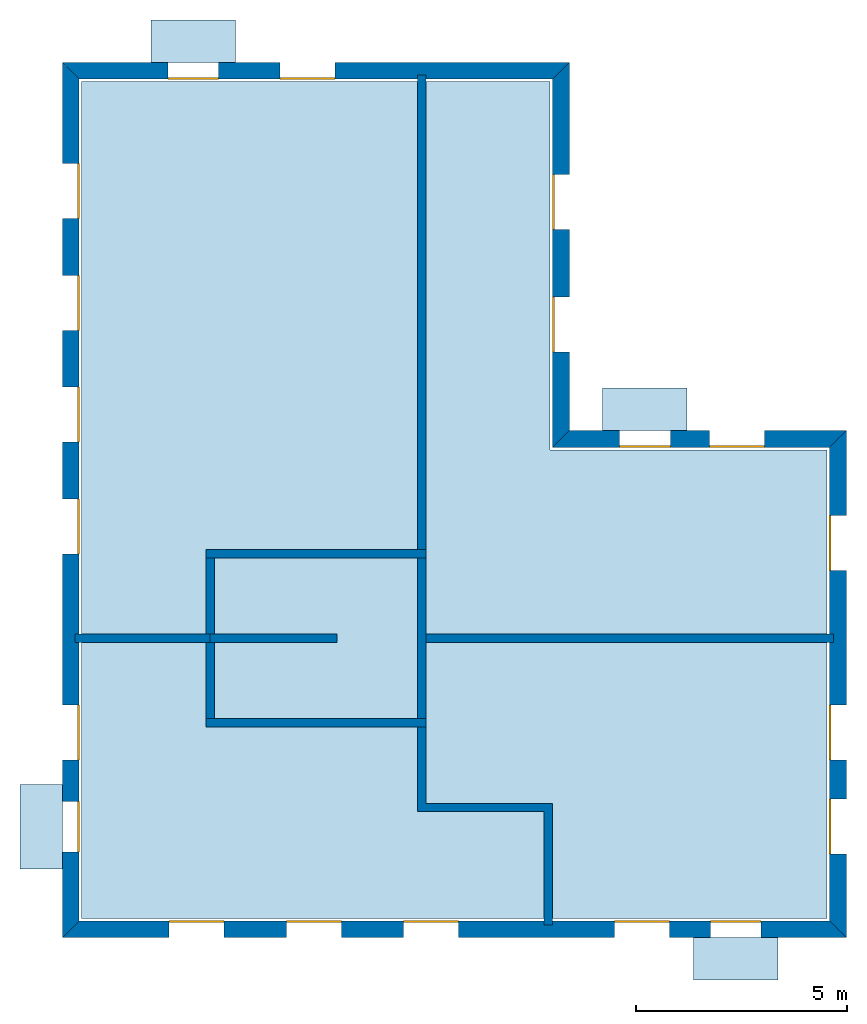
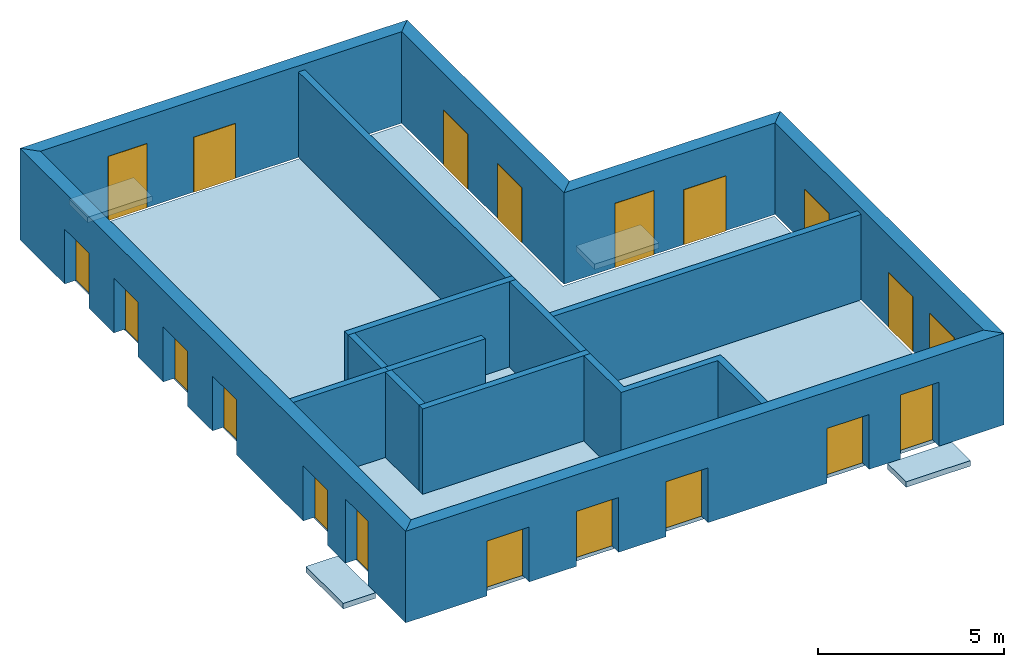
# One storey: 20 windows, 15 walls, 5 slabs, 20 openings.
"""IFC4 building model written with IfcOpenShell, lengths in metres."""

from ifc_helpers import new_model, si_unit, frame, origin_with_axes, place, context, subcontext, project, spatial, line, indexed_curve, outline, extrude, element, fill, save


model = new_model("IFC4")

# Units and contexts
model_context = context("Model", 3, precision=1e-05, world=origin_with_axes())
body_context = subcontext(model_context, "Body", "Model", "MODEL_VIEW")
ifc_project = project(units=[si_unit("AREAUNIT", "SQUARE_METRE"), si_unit("VOLUMEUNIT", "CUBIC_METRE"), si_unit("LENGTHUNIT", "METRE")], contexts=[model_context])

# Site, building, storey
site = spatial("IfcSite", under=ifc_project)
building = spatial("IfcBuilding", under=site, Name="Building 2")
storey_placement = place(None, frame((0.0, 0.0, 4.0), z_axis=(0.0, 0.0, 1.0), x_axis=(1.0, 0.0, 0.0)))
storey = spatial("IfcBuildingStorey", under=building, at=storey_placement, Name="02 Storey")

# Slabs
slab_1_placement = place(storey_placement, origin_with_axes())
element("IfcSlab", 1, at=slab_1_placement, inside=storey, Name="Slab", context=body_context, shape_type="SweptSolid", body=[
    extrude(outline(indexed_curve([(22.079464, -3.619175), (15.533354, -3.619175), (15.533354, 5.0882), (4.453354, 5.0882), (4.453354, -14.699175), (22.079464, -14.699175)], segments=[line(1, 2), line(2, 3), line(3, 4), line(4, 5), line(5, 6)])), origin_with_axes(), (0.0, 0.0, -1.0), 0.2),
])
slab_2_placement = place(storey_placement, origin_with_axes())
element("IfcSlab", 2, at=slab_2_placement, inside=storey, Name="Balcony", context=body_context, shape_type="SweptSolid", body=[
    extrude(outline(indexed_curve([(6.093354, 5.5482), (6.093354, 6.5482), (8.093354, 6.5482), (8.093354, 5.5482)], segments=[line(1, 2), line(2, 3), line(3, 4)])), origin_with_axes(), (0.0, 0.0, -1.0), 0.18),
])
slab_3_placement = place(storey_placement, origin_with_axes())
element("IfcSlab", 3, at=slab_3_placement, inside=storey, Name="Balcony", context=body_context, shape_type="SweptSolid", body=[
    extrude(outline(indexed_curve([(16.7753906666667, -3.159175), (16.7753906666667, -2.159175), (18.7753906666667, -2.159175), (18.7753906666667, -3.159175)], segments=[line(1, 2), line(2, 3), line(3, 4)])), origin_with_axes(), (0.0, 0.0, -1.0), 0.18),
])
slab_4_placement = place(storey_placement, origin_with_axes())
element("IfcSlab", 4, at=slab_4_placement, inside=storey, Name="Balcony", context=body_context, shape_type="SweptSolid", body=[
    extrude(outline(indexed_curve([(20.924094, -15.159175), (20.924094, -16.159175), (18.924094, -16.159175), (18.924094, -15.159175)], segments=[line(1, 2), line(2, 3), line(3, 4)])), origin_with_axes(), (0.0, 0.0, -1.0), 0.18),
])
slab_5_placement = place(storey_placement, origin_with_axes())
element("IfcSlab", 5, at=slab_5_placement, inside=storey, Name="Balcony", context=body_context, shape_type="SweptSolid", body=[
    extrude(outline(indexed_curve([(3.993354, -13.5322976666667), (2.993354, -13.5322976666667), (2.993354, -11.5322976666667), (3.993354, -11.5322976666667)], segments=[line(1, 2), line(2, 3), line(3, 4)])), origin_with_axes(), (0.0, 0.0, -1.0), 0.18),
])

# Walls
wall_1_placement = place(storey_placement, origin_with_axes())
element("IfcWall", 6, at=wall_1_placement, inside=storey, Name="Wall", context=body_context, shape_type="SweptSolid", body=[
    extrude(outline(indexed_curve([(7.593354, -7.978543), (4.293354, -7.978543), (4.293354, -8.178543), (7.593354, -8.178543)], segments=[line(1, 2), line(2, 3), line(3, 4)])), origin_with_axes(), (0.0, 0.0, 1.0), 2.8),
])
wall_2_placement = place(storey_placement, origin_with_axes())
element("IfcWall", 7, at=wall_2_placement, inside=storey, Name="Wall", context=body_context, shape_type="SweptSolid", body=[
    extrude(outline(indexed_curve([(12.593354, 5.2482), (12.393354, 5.2482), (12.393354, -6.178543), (12.593354, -6.178543)], segments=[line(1, 2), line(2, 3), line(3, 4)])), origin_with_axes(), (0.0, 0.0, 1.0), 2.8),
])
wall_3_placement = place(storey_placement, origin_with_axes())
element("IfcWall", 8, at=wall_3_placement, inside=storey, Name="Wall", context=body_context, shape_type="SweptSolid", body=[
    extrude(outline(indexed_curve([(22.239464, -7.978543), (12.393354, -7.978543), (12.393354, -8.178543), (22.239464, -8.178543)], segments=[line(1, 2), line(2, 3), line(3, 4)])), origin_with_axes(), (0.0, 0.0, 1.0), 2.8),
])
wall_4_placement = place(storey_placement, origin_with_axes())
element("IfcWall", 9, at=wall_4_placement, inside=storey, Name="Wall", context=body_context, shape_type="SweptSolid", body=[
    extrude(outline(indexed_curve([(15.593354, -11.978543), (12.593354, -11.978543), (12.593354, -9.978543), (12.393354, -9.978543), (12.393354, -12.178543), (15.393354, -12.178543), (15.393354, -14.859175), (15.593354, -14.859175)], segments=[line(1, 2), line(2, 3), line(3, 4), line(4, 5), line(5, 6), line(6, 7), line(7, 8)])), origin_with_axes(), (0.0, 0.0, 1.0), 2.8),
])

# Wall, openings, windows
wall_5_placement = place(storey_placement, origin_with_axes())
wall_5 = element("IfcWall", 10, at=wall_5_placement, inside=storey, Name="Facade", context=body_context, shape_type="SweptSolid", body=[
    extrude(outline(indexed_curve([(22.139464, -3.559175), (15.593354, -3.559175), (15.993354, -3.159175), (22.539464, -3.159175)], segments=[line(1, 2), line(2, 3), line(3, 4)])), origin_with_axes(), (0.0, 0.0, 1.0), 3.0),
])
opening_1_placement = place(wall_5_placement, origin_with_axes())
opening_1 = element("IfcOpeningElement", 11, at=opening_1_placement, cuts=wall_5, Name="Opening", context=body_context, shape_type="SweptSolid", body=[
    extrude(outline(indexed_curve([(20.6074273333333, -3.119175), (20.6074273333333, -3.619175), (19.3074273333333, -3.619175), (19.3074273333333, -3.119175)], segments=[line(1, 2), line(2, 3), line(3, 4)])), origin_with_axes(), (0.0, 0.0, 1.0), 1.8),
])
opening_2_placement = place(wall_5_placement, origin_with_axes())
opening_2 = element("IfcOpeningElement", 12, at=opening_2_placement, cuts=wall_5, Name="Opening", context=body_context, shape_type="SweptSolid", body=[
    extrude(outline(indexed_curve([(18.3753906666667, -3.119175), (18.3753906666667, -3.619175), (17.1753906666667, -3.619175), (17.1753906666667, -3.119175)], segments=[line(1, 2), line(2, 3), line(3, 4)])), origin_with_axes(), (0.0, 0.0, 1.0), 2.1),
])
window_1_placement = place(storey_placement, origin_with_axes())
window_1 = element("IfcWindow", 13, at=window_1_placement, inside=storey, Name="Window", PredefinedType="WINDOW", context=body_context, shape_type="SweptSolid", body=[
    extrude(outline(indexed_curve([(20.6074273333333, -3.519175), (20.6074273333333, -3.569175), (19.3074273333333, -3.569175), (19.3074273333333, -3.519175)], segments=[line(1, 2), line(2, 3), line(3, 4)])), origin_with_axes(), (0.0, 0.0, 1.0), 1.8),
])
fill(opening_1, window_1)
window_2_placement = place(storey_placement, origin_with_axes())
window_2 = element("IfcWindow", 14, at=window_2_placement, inside=storey, Name="Window", PredefinedType="WINDOW", context=body_context, shape_type="SweptSolid", body=[
    extrude(outline(indexed_curve([(18.3753906666667, -3.519175), (18.3753906666667, -3.569175), (17.1753906666667, -3.569175), (17.1753906666667, -3.519175)], segments=[line(1, 2), line(2, 3), line(3, 4)])), origin_with_axes(), (0.0, 0.0, 1.0), 2.1),
])
fill(opening_2, window_2)

wall_6_placement = place(storey_placement, origin_with_axes())
wall_6 = element("IfcWall", 15, at=wall_6_placement, inside=storey, Name="Facade", context=body_context, shape_type="SweptSolid", body=[
    extrude(outline(indexed_curve([(15.593354, -3.559175), (15.593354, 5.1482), (15.993354, 5.5482), (15.993354, -3.159175)], segments=[line(1, 2), line(2, 3), line(3, 4)])), origin_with_axes(), (0.0, 0.0, 1.0), 3.0),
])
opening_3_placement = place(wall_6_placement, origin_with_axes())
opening_3 = element("IfcOpeningElement", 16, at=opening_3_placement, cuts=wall_6, Name="Opening", context=body_context, shape_type="SweptSolid", body=[
    extrude(outline(indexed_curve([(16.033354, -1.30671666666667), (15.533354, -1.30671666666667), (15.533354, -0.00671666666666659), (16.033354, -0.00671666666666659)], segments=[line(1, 2), line(2, 3), line(3, 4)])), origin_with_axes(), (0.0, 0.0, 1.0), 1.8),
])
opening_4_placement = place(wall_6_placement, origin_with_axes())
opening_4 = element("IfcOpeningElement", 17, at=opening_4_placement, cuts=wall_6, Name="Opening", context=body_context, shape_type="SweptSolid", body=[
    extrude(outline(indexed_curve([(16.033354, 1.59574166666667), (15.533354, 1.59574166666667), (15.533354, 2.89574166666667), (16.033354, 2.89574166666667)], segments=[line(1, 2), line(2, 3), line(3, 4)])), origin_with_axes(), (0.0, 0.0, 1.0), 1.8),
])
window_3_placement = place(storey_placement, origin_with_axes())
window_3 = element("IfcWindow", 18, at=window_3_placement, inside=storey, Name="Window", PredefinedType="WINDOW", context=body_context, shape_type="SweptSolid", body=[
    extrude(outline(indexed_curve([(15.633354, -1.30671666666667), (15.583354, -1.30671666666667), (15.583354, -0.00671666666666659), (15.633354, -0.00671666666666659)], segments=[line(1, 2), line(2, 3), line(3, 4)])), origin_with_axes(), (0.0, 0.0, 1.0), 1.8),
])
fill(opening_3, window_3)
window_4_placement = place(storey_placement, origin_with_axes())
window_4 = element("IfcWindow", 19, at=window_4_placement, inside=storey, Name="Window", PredefinedType="WINDOW", context=body_context, shape_type="SweptSolid", body=[
    extrude(outline(indexed_curve([(15.633354, 1.59574166666667), (15.583354, 1.59574166666667), (15.583354, 2.89574166666667), (15.633354, 2.89574166666667)], segments=[line(1, 2), line(2, 3), line(3, 4)])), origin_with_axes(), (0.0, 0.0, 1.0), 1.8),
])
fill(opening_4, window_4)

wall_7_placement = place(storey_placement, origin_with_axes())
wall_7 = element("IfcWall", 20, at=wall_7_placement, inside=storey, Name="Facade", context=body_context, shape_type="SweptSolid", body=[
    extrude(outline(indexed_curve([(15.593354, 5.1482), (4.393354, 5.1482), (3.993354, 5.5482), (15.993354, 5.5482)], segments=[line(1, 2), line(2, 3), line(3, 4)])), origin_with_axes(), (0.0, 0.0, 1.0), 3.0),
])
opening_5_placement = place(wall_7_placement, origin_with_axes())
opening_5 = element("IfcOpeningElement", 21, at=opening_5_placement, cuts=wall_7, Name="Opening", context=body_context, shape_type="SweptSolid", body=[
    extrude(outline(indexed_curve([(10.443354, 5.5882), (10.443354, 5.0882), (9.143354, 5.0882), (9.143354, 5.5882)], segments=[line(1, 2), line(2, 3), line(3, 4)])), origin_with_axes(), (0.0, 0.0, 1.0), 1.8),
])
opening_6_placement = place(wall_7_placement, origin_with_axes())
opening_6 = element("IfcOpeningElement", 22, at=opening_6_placement, cuts=wall_7, Name="Opening", context=body_context, shape_type="SweptSolid", body=[
    extrude(outline(indexed_curve([(7.693354, 5.5882), (7.693354, 5.0882), (6.493354, 5.0882), (6.493354, 5.5882)], segments=[line(1, 2), line(2, 3), line(3, 4)])), origin_with_axes(), (0.0, 0.0, 1.0), 2.1),
])
window_5_placement = place(storey_placement, origin_with_axes())
window_5 = element("IfcWindow", 23, at=window_5_placement, inside=storey, Name="Window", PredefinedType="WINDOW", context=body_context, shape_type="SweptSolid", body=[
    extrude(outline(indexed_curve([(10.443354, 5.1882), (10.443354, 5.1382), (9.143354, 5.1382), (9.143354, 5.1882)], segments=[line(1, 2), line(2, 3), line(3, 4)])), origin_with_axes(), (0.0, 0.0, 1.0), 1.8),
])
fill(opening_5, window_5)
window_6_placement = place(storey_placement, origin_with_axes())
window_6 = element("IfcWindow", 24, at=window_6_placement, inside=storey, Name="Window", PredefinedType="WINDOW", context=body_context, shape_type="SweptSolid", body=[
    extrude(outline(indexed_curve([(7.693354, 5.1882), (7.693354, 5.1382), (6.493354, 5.1382), (6.493354, 5.1882)], segments=[line(1, 2), line(2, 3), line(3, 4)])), origin_with_axes(), (0.0, 0.0, 1.0), 2.1),
])
fill(opening_6, window_6)

wall_8_placement = place(storey_placement, origin_with_axes())
wall_8 = element("IfcWall", 25, at=wall_8_placement, inside=storey, Name="Facade", context=body_context, shape_type="SweptSolid", body=[
    extrude(outline(indexed_curve([(4.393354, 5.1482), (4.393354, -14.759175), (3.993354, -15.159175), (3.993354, 5.5482)], segments=[line(1, 2), line(2, 3), line(3, 4)])), origin_with_axes(), (0.0, 0.0, 1.0), 3.0),
])
opening_7_placement = place(wall_8_placement, origin_with_axes())
opening_7 = element("IfcOpeningElement", 26, at=opening_7_placement, cuts=wall_8, Name="Opening", context=body_context, shape_type="SweptSolid", body=[
    extrude(outline(indexed_curve([(3.953354, 3.1528514), (4.453354, 3.1528514), (4.453354, 1.8528514), (3.953354, 1.8528514)], segments=[line(1, 2), line(2, 3), line(3, 4)])), origin_with_axes(), (0.0, 0.0, 1.0), 1.8),
])
opening_8_placement = place(wall_8_placement, origin_with_axes())
opening_8 = element("IfcOpeningElement", 27, at=opening_8_placement, cuts=wall_8, Name="Opening", context=body_context, shape_type="SweptSolid", body=[
    extrude(outline(indexed_curve([(3.953354, 0.507502800000001), (4.453354, 0.507502800000001), (4.453354, -0.792497199999999), (3.953354, -0.792497199999999)], segments=[line(1, 2), line(2, 3), line(3, 4)])), origin_with_axes(), (0.0, 0.0, 1.0), 1.8),
])
opening_9_placement = place(wall_8_placement, origin_with_axes())
opening_9 = element("IfcOpeningElement", 28, at=opening_9_placement, cuts=wall_8, Name="Opening", context=body_context, shape_type="SweptSolid", body=[
    extrude(outline(indexed_curve([(3.953354, -2.1378458), (4.453354, -2.1378458), (4.453354, -3.4378458), (3.953354, -3.4378458)], segments=[line(1, 2), line(2, 3), line(3, 4)])), origin_with_axes(), (0.0, 0.0, 1.0), 1.8),
])
opening_10_placement = place(wall_8_placement, origin_with_axes())
opening_10 = element("IfcOpeningElement", 29, at=opening_10_placement, cuts=wall_8, Name="Opening", context=body_context, shape_type="SweptSolid", body=[
    extrude(outline(indexed_curve([(3.953354, -4.7831944), (4.453354, -4.7831944), (4.453354, -6.0831944), (3.953354, -6.0831944)], segments=[line(1, 2), line(2, 3), line(3, 4)])), origin_with_axes(), (0.0, 0.0, 1.0), 1.8),
])
opening_11_placement = place(wall_8_placement, origin_with_axes())
opening_11 = element("IfcOpeningElement", 30, at=opening_11_placement, cuts=wall_8, Name="Opening", context=body_context, shape_type="SweptSolid", body=[
    extrude(outline(indexed_curve([(3.953354, -9.65542033333333), (4.453354, -9.65542033333333), (4.453354, -10.9554203333333), (3.953354, -10.9554203333333)], segments=[line(1, 2), line(2, 3), line(3, 4)])), origin_with_axes(), (0.0, 0.0, 1.0), 1.8),
])
opening_12_placement = place(wall_8_placement, origin_with_axes())
opening_12 = element("IfcOpeningElement", 31, at=opening_12_placement, cuts=wall_8, Name="Opening", context=body_context, shape_type="SweptSolid", body=[
    extrude(outline(indexed_curve([(3.953354, -11.9322976666667), (4.453354, -11.9322976666667), (4.453354, -13.1322976666667), (3.953354, -13.1322976666667)], segments=[line(1, 2), line(2, 3), line(3, 4)])), origin_with_axes(), (0.0, 0.0, 1.0), 2.1),
])
window_7_placement = place(storey_placement, origin_with_axes())
window_7 = element("IfcWindow", 32, at=window_7_placement, inside=storey, Name="Window", PredefinedType="WINDOW", context=body_context, shape_type="SweptSolid", body=[
    extrude(outline(indexed_curve([(4.353354, 3.1528514), (4.403354, 3.1528514), (4.403354, 1.8528514), (4.353354, 1.8528514)], segments=[line(1, 2), line(2, 3), line(3, 4)])), origin_with_axes(), (0.0, 0.0, 1.0), 1.8),
])
fill(opening_7, window_7)
window_8_placement = place(storey_placement, origin_with_axes())
window_8 = element("IfcWindow", 33, at=window_8_placement, inside=storey, Name="Window", PredefinedType="WINDOW", context=body_context, shape_type="SweptSolid", body=[
    extrude(outline(indexed_curve([(4.353354, 0.507502800000001), (4.403354, 0.507502800000001), (4.403354, -0.792497199999999), (4.353354, -0.792497199999999)], segments=[line(1, 2), line(2, 3), line(3, 4)])), origin_with_axes(), (0.0, 0.0, 1.0), 1.8),
])
fill(opening_8, window_8)
window_9_placement = place(storey_placement, origin_with_axes())
window_9 = element("IfcWindow", 34, at=window_9_placement, inside=storey, Name="Window", PredefinedType="WINDOW", context=body_context, shape_type="SweptSolid", body=[
    extrude(outline(indexed_curve([(4.353354, -2.1378458), (4.403354, -2.1378458), (4.403354, -3.4378458), (4.353354, -3.4378458)], segments=[line(1, 2), line(2, 3), line(3, 4)])), origin_with_axes(), (0.0, 0.0, 1.0), 1.8),
])
fill(opening_9, window_9)
window_10_placement = place(storey_placement, origin_with_axes())
window_10 = element("IfcWindow", 35, at=window_10_placement, inside=storey, Name="Window", PredefinedType="WINDOW", context=body_context, shape_type="SweptSolid", body=[
    extrude(outline(indexed_curve([(4.353354, -4.7831944), (4.403354, -4.7831944), (4.403354, -6.0831944), (4.353354, -6.0831944)], segments=[line(1, 2), line(2, 3), line(3, 4)])), origin_with_axes(), (0.0, 0.0, 1.0), 1.8),
])
fill(opening_10, window_10)
window_11_placement = place(storey_placement, origin_with_axes())
window_11 = element("IfcWindow", 36, at=window_11_placement, inside=storey, Name="Window", PredefinedType="WINDOW", context=body_context, shape_type="SweptSolid", body=[
    extrude(outline(indexed_curve([(4.353354, -9.65542033333333), (4.403354, -9.65542033333333), (4.403354, -10.9554203333333), (4.353354, -10.9554203333333)], segments=[line(1, 2), line(2, 3), line(3, 4)])), origin_with_axes(), (0.0, 0.0, 1.0), 1.8),
])
fill(opening_11, window_11)
window_12_placement = place(storey_placement, origin_with_axes())
window_12 = element("IfcWindow", 37, at=window_12_placement, inside=storey, Name="Window", PredefinedType="WINDOW", context=body_context, shape_type="SweptSolid", body=[
    extrude(outline(indexed_curve([(4.353354, -11.9322976666667), (4.403354, -11.9322976666667), (4.403354, -13.1322976666667), (4.353354, -13.1322976666667)], segments=[line(1, 2), line(2, 3), line(3, 4)])), origin_with_axes(), (0.0, 0.0, 1.0), 2.1),
])
fill(opening_12, window_12)

wall_9_placement = place(storey_placement, origin_with_axes())
wall_9 = element("IfcWall", 38, at=wall_9_placement, inside=storey, Name="Facade", context=body_context, shape_type="SweptSolid", body=[
    extrude(outline(indexed_curve([(4.393354, -14.759175), (22.139464, -14.759175), (22.539464, -15.159175), (3.993354, -15.159175)], segments=[line(1, 2), line(2, 3), line(3, 4)])), origin_with_axes(), (0.0, 0.0, 1.0), 3.0),
])
opening_13_placement = place(wall_9_placement, origin_with_axes())
opening_13 = element("IfcOpeningElement", 39, at=opening_13_placement, cuts=wall_9, Name="Opening", context=body_context, shape_type="SweptSolid", body=[
    extrude(outline(indexed_curve([(17.058724, -15.199175), (17.058724, -14.699175), (18.358724, -14.699175), (18.358724, -15.199175)], segments=[line(1, 2), line(2, 3), line(3, 4)])), origin_with_axes(), (0.0, 0.0, 1.0), 1.8),
])
opening_14_placement = place(wall_9_placement, origin_with_axes())
opening_14 = element("IfcOpeningElement", 40, at=opening_14_placement, cuts=wall_9, Name="Opening", context=body_context, shape_type="SweptSolid", body=[
    extrude(outline(indexed_curve([(19.324094, -15.199175), (19.324094, -14.699175), (20.524094, -14.699175), (20.524094, -15.199175)], segments=[line(1, 2), line(2, 3), line(3, 4)])), origin_with_axes(), (0.0, 0.0, 1.0), 2.1),
])
opening_15_placement = place(wall_9_placement, origin_with_axes())
opening_15 = element("IfcOpeningElement", 41, at=opening_15_placement, cuts=wall_9, Name="Opening", context=body_context, shape_type="SweptSolid", body=[
    extrude(outline(indexed_curve([(6.518354, -15.199175), (6.518354, -14.699175), (7.818354, -14.699175), (7.818354, -15.199175)], segments=[line(1, 2), line(2, 3), line(3, 4)])), origin_with_axes(), (0.0, 0.0, 1.0), 1.8),
])
opening_16_placement = place(wall_9_placement, origin_with_axes())
opening_16 = element("IfcOpeningElement", 42, at=opening_16_placement, cuts=wall_9, Name="Opening", context=body_context, shape_type="SweptSolid", body=[
    extrude(outline(indexed_curve([(9.293354, -15.199175), (9.293354, -14.699175), (10.593354, -14.699175), (10.593354, -15.199175)], segments=[line(1, 2), line(2, 3), line(3, 4)])), origin_with_axes(), (0.0, 0.0, 1.0), 1.8),
])
opening_17_placement = place(wall_9_placement, origin_with_axes())
opening_17 = element("IfcOpeningElement", 43, at=opening_17_placement, cuts=wall_9, Name="Opening", context=body_context, shape_type="SweptSolid", body=[
    extrude(outline(indexed_curve([(12.068354, -15.199175), (12.068354, -14.699175), (13.368354, -14.699175), (13.368354, -15.199175)], segments=[line(1, 2), line(2, 3), line(3, 4)])), origin_with_axes(), (0.0, 0.0, 1.0), 1.8),
])
window_13_placement = place(storey_placement, origin_with_axes())
window_13 = element("IfcWindow", 44, at=window_13_placement, inside=storey, Name="Window", PredefinedType="WINDOW", context=body_context, shape_type="SweptSolid", body=[
    extrude(outline(indexed_curve([(17.058724, -14.799175), (17.058724, -14.749175), (18.358724, -14.749175), (18.358724, -14.799175)], segments=[line(1, 2), line(2, 3), line(3, 4)])), origin_with_axes(), (0.0, 0.0, 1.0), 1.8),
])
fill(opening_13, window_13)
window_14_placement = place(storey_placement, origin_with_axes())
window_14 = element("IfcWindow", 45, at=window_14_placement, inside=storey, Name="Window", PredefinedType="WINDOW", context=body_context, shape_type="SweptSolid", body=[
    extrude(outline(indexed_curve([(19.324094, -14.799175), (19.324094, -14.749175), (20.524094, -14.749175), (20.524094, -14.799175)], segments=[line(1, 2), line(2, 3), line(3, 4)])), origin_with_axes(), (0.0, 0.0, 1.0), 2.1),
])
fill(opening_14, window_14)
window_15_placement = place(storey_placement, origin_with_axes())
window_15 = element("IfcWindow", 46, at=window_15_placement, inside=storey, Name="Window", PredefinedType="WINDOW", context=body_context, shape_type="SweptSolid", body=[
    extrude(outline(indexed_curve([(6.518354, -14.799175), (6.518354, -14.749175), (7.818354, -14.749175), (7.818354, -14.799175)], segments=[line(1, 2), line(2, 3), line(3, 4)])), origin_with_axes(), (0.0, 0.0, 1.0), 1.8),
])
fill(opening_15, window_15)
window_16_placement = place(storey_placement, origin_with_axes())
window_16 = element("IfcWindow", 47, at=window_16_placement, inside=storey, Name="Window", PredefinedType="WINDOW", context=body_context, shape_type="SweptSolid", body=[
    extrude(outline(indexed_curve([(9.293354, -14.799175), (9.293354, -14.749175), (10.593354, -14.749175), (10.593354, -14.799175)], segments=[line(1, 2), line(2, 3), line(3, 4)])), origin_with_axes(), (0.0, 0.0, 1.0), 1.8),
])
fill(opening_16, window_16)
window_17_placement = place(storey_placement, origin_with_axes())
window_17 = element("IfcWindow", 48, at=window_17_placement, inside=storey, Name="Window", PredefinedType="WINDOW", context=body_context, shape_type="SweptSolid", body=[
    extrude(outline(indexed_curve([(12.068354, -14.799175), (12.068354, -14.749175), (13.368354, -14.749175), (13.368354, -14.799175)], segments=[line(1, 2), line(2, 3), line(3, 4)])), origin_with_axes(), (0.0, 0.0, 1.0), 1.8),
])
fill(opening_17, window_17)

wall_10_placement = place(storey_placement, origin_with_axes())
wall_10 = element("IfcWall", 49, at=wall_10_placement, inside=storey, Name="Facade", context=body_context, shape_type="SweptSolid", body=[
    extrude(outline(indexed_curve([(22.139464, -14.759175), (22.139464, -3.559175), (22.539464, -3.159175), (22.539464, -15.159175)], segments=[line(1, 2), line(2, 3), line(3, 4)])), origin_with_axes(), (0.0, 0.0, 1.0), 3.0),
])
opening_18_placement = place(wall_10_placement, origin_with_axes())
opening_18 = element("IfcOpeningElement", 50, at=opening_18_placement, cuts=wall_10, Name="Opening", context=body_context, shape_type="SweptSolid", body=[
    extrude(outline(indexed_curve([(22.579464, -6.468859), (22.079464, -6.468859), (22.079464, -5.168859), (22.579464, -5.168859)], segments=[line(1, 2), line(2, 3), line(3, 4)])), origin_with_axes(), (0.0, 0.0, 1.0), 1.8),
])
opening_19_placement = place(wall_10_placement, origin_with_axes())
opening_19 = element("IfcOpeningElement", 51, at=opening_19_placement, cuts=wall_10, Name="Opening", context=body_context, shape_type="SweptSolid", body=[
    extrude(outline(indexed_curve([(22.579464, -13.1822976666667), (22.079464, -13.1822976666667), (22.079464, -11.8822976666667), (22.579464, -11.8822976666667)], segments=[line(1, 2), line(2, 3), line(3, 4)])), origin_with_axes(), (0.0, 0.0, 1.0), 1.8),
])
opening_20_placement = place(wall_10_placement, origin_with_axes())
opening_20 = element("IfcOpeningElement", 52, at=opening_20_placement, cuts=wall_10, Name="Opening", context=body_context, shape_type="SweptSolid", body=[
    extrude(outline(indexed_curve([(22.579464, -10.9554203333333), (22.079464, -10.9554203333333), (22.079464, -9.65542033333333), (22.579464, -9.65542033333333)], segments=[line(1, 2), line(2, 3), line(3, 4)])), origin_with_axes(), (0.0, 0.0, 1.0), 1.8),
])
window_18_placement = place(storey_placement, origin_with_axes())
window_18 = element("IfcWindow", 53, at=window_18_placement, inside=storey, Name="Window", PredefinedType="WINDOW", context=body_context, shape_type="SweptSolid", body=[
    extrude(outline(indexed_curve([(22.179464, -6.468859), (22.129464, -6.468859), (22.129464, -5.168859), (22.179464, -5.168859)], segments=[line(1, 2), line(2, 3), line(3, 4)])), origin_with_axes(), (0.0, 0.0, 1.0), 1.8),
])
fill(opening_18, window_18)
window_19_placement = place(storey_placement, origin_with_axes())
window_19 = element("IfcWindow", 54, at=window_19_placement, inside=storey, Name="Window", PredefinedType="WINDOW", context=body_context, shape_type="SweptSolid", body=[
    extrude(outline(indexed_curve([(22.179464, -13.1822976666667), (22.129464, -13.1822976666667), (22.129464, -11.8822976666667), (22.179464, -11.8822976666667)], segments=[line(1, 2), line(2, 3), line(3, 4)])), origin_with_axes(), (0.0, 0.0, 1.0), 1.8),
])
fill(opening_19, window_19)
window_20_placement = place(storey_placement, origin_with_axes())
window_20 = element("IfcWindow", 55, at=window_20_placement, inside=storey, Name="Window", PredefinedType="WINDOW", context=body_context, shape_type="SweptSolid", body=[
    extrude(outline(indexed_curve([(22.179464, -10.9554203333333), (22.129464, -10.9554203333333), (22.129464, -9.65542033333333), (22.179464, -9.65542033333333)], segments=[line(1, 2), line(2, 3), line(3, 4)])), origin_with_axes(), (0.0, 0.0, 1.0), 1.8),
])
fill(opening_20, window_20)

# Walls
wall_11_placement = place(storey_placement, origin_with_axes())
element("IfcWall", 56, at=wall_11_placement, inside=storey, Name="CoreWall", context=body_context, shape_type="SweptSolid", body=[
    extrude(outline(indexed_curve([(12.593354, -5.978543), (7.393354, -5.978543), (7.393354, -6.178543), (12.593354, -6.178543)], segments=[line(1, 2), line(2, 3), line(3, 4)])), origin_with_axes(), (0.0, 0.0, 1.0), 2.8),
])
wall_12_placement = place(storey_placement, origin_with_axes())
element("IfcWall", 57, at=wall_12_placement, inside=storey, Name="CoreWall", context=body_context, shape_type="SweptSolid", body=[
    extrude(outline(indexed_curve([(7.393354, -10.178543), (12.593354, -10.178543), (12.593354, -9.978543), (7.393354, -9.978543)], segments=[line(1, 2), line(2, 3), line(3, 4)])), origin_with_axes(), (0.0, 0.0, 1.0), 2.8),
])
wall_13_placement = place(storey_placement, origin_with_axes())
element("IfcWall", 58, at=wall_13_placement, inside=storey, Name="CoreWall", context=body_context, shape_type="SweptSolid", body=[
    extrude(outline(indexed_curve([(7.593354, -9.978543), (7.593354, -6.178543), (7.393354, -6.178543), (7.393354, -9.978543)], segments=[line(1, 2), line(2, 3), line(3, 4)])), origin_with_axes(), (0.0, 0.0, 1.0), 2.8),
])
wall_14_placement = place(storey_placement, origin_with_axes())
element("IfcWall", 59, at=wall_14_placement, inside=storey, Name="CoreWall", context=body_context, shape_type="SweptSolid", body=[
    extrude(outline(indexed_curve([(12.393354, -6.178543), (12.393354, -9.978543), (12.593354, -9.978543), (12.593354, -6.178543)], segments=[line(1, 2), line(2, 3), line(3, 4)])), origin_with_axes(), (0.0, 0.0, 1.0), 2.8),
])
wall_15_placement = place(storey_placement, origin_with_axes())
element("IfcWall", 60, at=wall_15_placement, inside=storey, Name="CoreWall", context=body_context, shape_type="SweptSolid", body=[
    extrude(outline(indexed_curve([(10.493354, -7.978543), (7.493354, -7.978543), (7.493354, -8.178543), (10.493354, -8.178543)], segments=[line(1, 2), line(2, 3), line(3, 4)])), origin_with_axes(), (0.0, 0.0, 1.0), 2.8),
])

save(model, "model.ifc")
